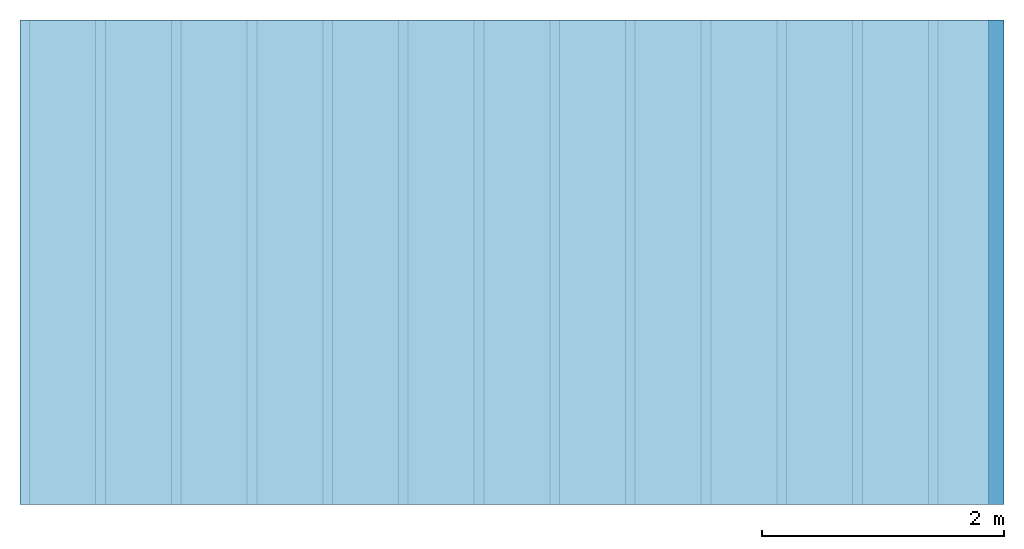
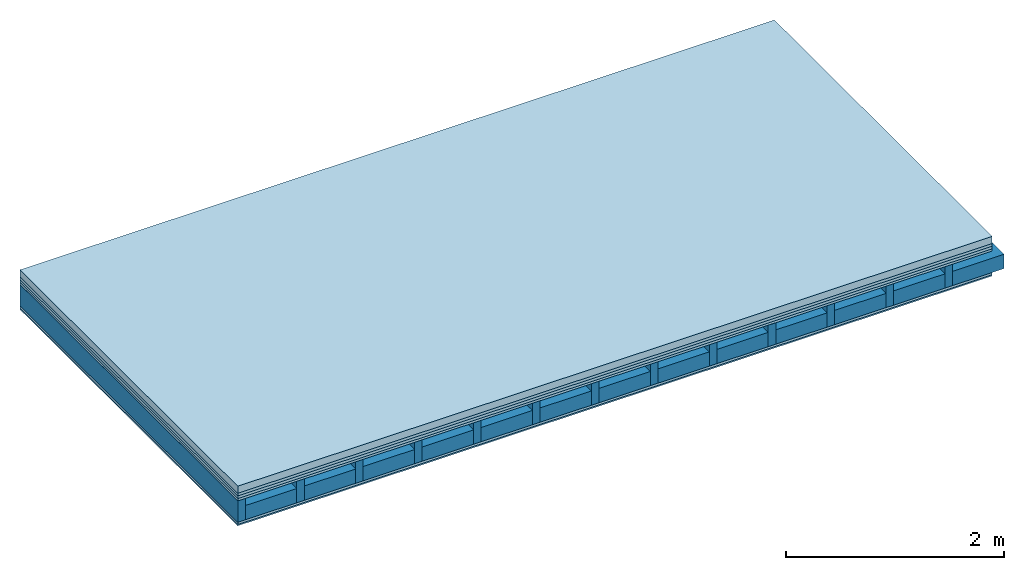
# One storey: 6 plates, 2 members, 1 element without a shape of its own.
"""IFC4 building model written with IfcOpenShell, lengths in metres."""

from ifc_helpers import new_model, si_unit, derived_unit, direction, frame, frame_2d, origin, origin_with_axes, place, context, project, spatial, rectangle, extrude, material, layer, layer_set, type_object, element, aggregate, save


model = new_model("IFC4")

# Units and contexts
plan_context = context("Plan", 3, precision=1e-05, world=origin(), true_north=direction((0.0, 1.0)))
model_context = context("Model", 3, precision=1e-05, world=origin(), true_north=direction((0.0, 1.0)))
ifc_project = project(units=[si_unit("LENGTHUNIT", "METRE"), derived_unit("SOUNDPRESSUREUNIT", [(si_unit("PRESSUREUNIT", "PASCAL", prefix="MICRO"), 0)]), si_unit("ENERGYUNIT", "JOULE", prefix="MEGA"), si_unit("MASSUNIT", "GRAM", prefix="KILO"), derived_unit("THERMALTRANSMITTANCEUNIT", [(si_unit("POWERUNIT", "WATT"), 1), (si_unit("AREAUNIT", "SQUARE_METRE"), -1), (si_unit("THERMODYNAMICTEMPERATUREUNIT", "KELVIN"), -1)]), derived_unit("AREADENSITYUNIT", [(si_unit("MASSUNIT", "GRAM", prefix="KILO"), 1), (si_unit("AREAUNIT", "SQUARE_METRE"), -1)]), derived_unit("USERDEFINED", [(si_unit("ENERGYUNIT", "JOULE", prefix="MEGA"), 1), (si_unit("AREAUNIT", "SQUARE_METRE"), -1)])], contexts=[plan_context, model_context])

# Site, building, storey
site = spatial("IfcSite", under=ifc_project)
building_placement = place(None, origin())
building = spatial("IfcBuilding", under=site, at=building_placement)
storey_placement = place(building_placement, origin())
storey = spatial("IfcBuildingStorey", under=building, at=storey_placement)

# Slab, members, plates
ifc_material_1 = material(Name="Cement screed", Category="04.006")
ifc_layer_1 = layer(ifc_material_1, 0.08, Name="On-material")
ifc_material_2 = material()
ifc_layer_2 = layer(ifc_material_2, 0.03, Name="Impact sound insulation")
ifc_material_3 = material()
ifc_layer_3 = layer(ifc_material_3, 0.03, Name="Additional insulation")
ifc_material_4 = material(Category="07.001")
ifc_layer_4 = layer(ifc_material_4, 0.025, Name="Sub-floor")
ifc_material_5 = material(Name="Rigid, of the art")
ifc_layer_5 = layer(ifc_material_5, 0.0, Name="Bond")
ifc_layer_6 = layer(None, 0.24, Name="Supporting structure")
ifc_layer_7 = layer(ifc_material_5, 0.0, Name="Bond")
ifc_layer_8 = layer(ifc_material_4, 0.025, Name="Lower layer 1")
ifc_material_6 = material(Category="03.007")
ifc_layer_9 = layer(ifc_material_6, 0.015, Name="Lower 2nd layer")
ifc_layer_set = layer_set([ifc_layer_1, ifc_layer_2, ifc_layer_3, ifc_layer_4, ifc_layer_5, ifc_layer_6, ifc_layer_7, ifc_layer_8, ifc_layer_9])
slab_type = type_object("IfcSlabType", Name="A0455", PredefinedType="NOTDEFINED", material=ifc_layer_set)
slab_placement = place(None, frame((0.0, 0.0, 0.0), z_axis=(0.0, 0.0, -1.0), x_axis=(1.0, 0.0, 0.0)))
slab = element("IfcSlab", 1, at=slab_placement, inside=storey, type_object=slab_type, material=ifc_layer_set, Name="Slab #1")
ifc_material_7 = material()
member_1_placement = place(slab_placement, origin())
member_1 = element("IfcMember", 2, at=member_1_placement, material=ifc_material_7, Name="Supporting structure", context=plan_context, shape_type="SweptSolid", body=[
    extrude(rectangle(XDim=0.08, YDim=0.24, at=frame_2d((0.04, 0.12), x_axis=(1.0, 0.0))), frame((0.0, 4.0, 0.165), z_axis=(0.0, -1.0, 0.0), x_axis=(1.0, 0.0, 0.0)), (0.0, 0.0, 1.0), 4.0),
    extrude(rectangle(XDim=0.08, YDim=0.24, at=frame_2d((0.04, 0.12), x_axis=(1.0, 0.0))), frame((0.625, 4.0, 0.165), z_axis=(0.0, -1.0, 0.0), x_axis=(1.0, 0.0, 0.0)), (0.0, 0.0, 1.0), 4.0),
    extrude(rectangle(XDim=0.08, YDim=0.24, at=frame_2d((0.04, 0.12), x_axis=(1.0, 0.0))), frame((1.25, 4.0, 0.165), z_axis=(0.0, -1.0, 0.0), x_axis=(1.0, 0.0, 0.0)), (0.0, 0.0, 1.0), 4.0),
    extrude(rectangle(XDim=0.08, YDim=0.24, at=frame_2d((0.04, 0.12), x_axis=(1.0, 0.0))), frame((1.875, 4.0, 0.165), z_axis=(0.0, -1.0, 0.0), x_axis=(1.0, 0.0, 0.0)), (0.0, 0.0, 1.0), 4.0),
    extrude(rectangle(XDim=0.08, YDim=0.24, at=frame_2d((0.04, 0.12), x_axis=(1.0, 0.0))), frame((2.5, 4.0, 0.165), z_axis=(0.0, -1.0, 0.0), x_axis=(1.0, 0.0, 0.0)), (0.0, 0.0, 1.0), 4.0),
    extrude(rectangle(XDim=0.08, YDim=0.24, at=frame_2d((0.04, 0.12), x_axis=(1.0, 0.0))), frame((3.125, 4.0, 0.165), z_axis=(0.0, -1.0, 0.0), x_axis=(1.0, 0.0, 0.0)), (0.0, 0.0, 1.0), 4.0),
    extrude(rectangle(XDim=0.08, YDim=0.24, at=frame_2d((0.04, 0.12), x_axis=(1.0, 0.0))), frame((3.75, 4.0, 0.165), z_axis=(0.0, -1.0, 0.0), x_axis=(1.0, 0.0, 0.0)), (0.0, 0.0, 1.0), 4.0),
    extrude(rectangle(XDim=0.08, YDim=0.24, at=frame_2d((0.04, 0.12), x_axis=(1.0, 0.0))), frame((4.375, 4.0, 0.165), z_axis=(0.0, -1.0, 0.0), x_axis=(1.0, 0.0, 0.0)), (0.0, 0.0, 1.0), 4.0),
    extrude(rectangle(XDim=0.08, YDim=0.24, at=frame_2d((0.04, 0.12), x_axis=(1.0, 0.0))), frame((5.0, 4.0, 0.165), z_axis=(0.0, -1.0, 0.0), x_axis=(1.0, 0.0, 0.0)), (0.0, 0.0, 1.0), 4.0),
    extrude(rectangle(XDim=0.08, YDim=0.24, at=frame_2d((0.04, 0.12), x_axis=(1.0, 0.0))), frame((5.625, 4.0, 0.165), z_axis=(0.0, -1.0, 0.0), x_axis=(1.0, 0.0, 0.0)), (0.0, 0.0, 1.0), 4.0),
    extrude(rectangle(XDim=0.08, YDim=0.24, at=frame_2d((0.04, 0.12), x_axis=(1.0, 0.0))), frame((6.25, 4.0, 0.165), z_axis=(0.0, -1.0, 0.0), x_axis=(1.0, 0.0, 0.0)), (0.0, 0.0, 1.0), 4.0),
    extrude(rectangle(XDim=0.08, YDim=0.24, at=frame_2d((0.04, 0.12), x_axis=(1.0, 0.0))), frame((6.875, 4.0, 0.165), z_axis=(0.0, -1.0, 0.0), x_axis=(1.0, 0.0, 0.0)), (0.0, 0.0, 1.0), 4.0),
    extrude(rectangle(XDim=0.08, YDim=0.24, at=frame_2d((0.04, 0.12), x_axis=(1.0, 0.0))), frame((7.5, 4.0, 0.165), z_axis=(0.0, -1.0, 0.0), x_axis=(1.0, 0.0, 0.0)), (0.0, 0.0, 1.0), 4.0),
])
ifc_material_8 = material()
member_2_placement = place(slab_placement, origin())
member_2 = element("IfcMember", 3, at=member_2_placement, material=ifc_material_8, Name="in supporting structure", context=plan_context, shape_type="SweptSolid", body=[
    extrude(rectangle(XDim=0.545, YDim=0.16, at=frame_2d((0.2725, 0.08), x_axis=(1.0, 0.0))), frame((0.08, 4.0, 0.245), z_axis=(0.0, -1.0, 0.0), x_axis=(1.0, 0.0, 0.0)), (0.0, 0.0, 1.0), 4.0),
    extrude(rectangle(XDim=0.545, YDim=0.16, at=frame_2d((0.2725, 0.08), x_axis=(1.0, 0.0))), frame((0.705, 4.0, 0.245), z_axis=(0.0, -1.0, 0.0), x_axis=(1.0, 0.0, 0.0)), (0.0, 0.0, 1.0), 4.0),
    extrude(rectangle(XDim=0.545, YDim=0.16, at=frame_2d((0.2725, 0.08), x_axis=(1.0, 0.0))), frame((1.33, 4.0, 0.245), z_axis=(0.0, -1.0, 0.0), x_axis=(1.0, 0.0, 0.0)), (0.0, 0.0, 1.0), 4.0),
    extrude(rectangle(XDim=0.545, YDim=0.16, at=frame_2d((0.2725, 0.08), x_axis=(1.0, 0.0))), frame((1.955, 4.0, 0.245), z_axis=(0.0, -1.0, 0.0), x_axis=(1.0, 0.0, 0.0)), (0.0, 0.0, 1.0), 4.0),
    extrude(rectangle(XDim=0.545, YDim=0.16, at=frame_2d((0.2725, 0.08), x_axis=(1.0, 0.0))), frame((2.58, 4.0, 0.245), z_axis=(0.0, -1.0, 0.0), x_axis=(1.0, 0.0, 0.0)), (0.0, 0.0, 1.0), 4.0),
    extrude(rectangle(XDim=0.545, YDim=0.16, at=frame_2d((0.2725, 0.08), x_axis=(1.0, 0.0))), frame((3.205, 4.0, 0.245), z_axis=(0.0, -1.0, 0.0), x_axis=(1.0, 0.0, 0.0)), (0.0, 0.0, 1.0), 4.0),
    extrude(rectangle(XDim=0.545, YDim=0.16, at=frame_2d((0.2725, 0.08), x_axis=(1.0, 0.0))), frame((3.83, 4.0, 0.245), z_axis=(0.0, -1.0, 0.0), x_axis=(1.0, 0.0, 0.0)), (0.0, 0.0, 1.0), 4.0),
    extrude(rectangle(XDim=0.545, YDim=0.16, at=frame_2d((0.2725, 0.08), x_axis=(1.0, 0.0))), frame((4.455, 4.0, 0.245), z_axis=(0.0, -1.0, 0.0), x_axis=(1.0, 0.0, 0.0)), (0.0, 0.0, 1.0), 4.0),
    extrude(rectangle(XDim=0.545, YDim=0.16, at=frame_2d((0.2725, 0.08), x_axis=(1.0, 0.0))), frame((5.08, 4.0, 0.245), z_axis=(0.0, -1.0, 0.0), x_axis=(1.0, 0.0, 0.0)), (0.0, 0.0, 1.0), 4.0),
    extrude(rectangle(XDim=0.545, YDim=0.16, at=frame_2d((0.2725, 0.08), x_axis=(1.0, 0.0))), frame((5.705, 4.0, 0.245), z_axis=(0.0, -1.0, 0.0), x_axis=(1.0, 0.0, 0.0)), (0.0, 0.0, 1.0), 4.0),
    extrude(rectangle(XDim=0.545, YDim=0.16, at=frame_2d((0.2725, 0.08), x_axis=(1.0, 0.0))), frame((6.33, 4.0, 0.245), z_axis=(0.0, -1.0, 0.0), x_axis=(1.0, 0.0, 0.0)), (0.0, 0.0, 1.0), 4.0),
    extrude(rectangle(XDim=0.545, YDim=0.16, at=frame_2d((0.2725, 0.08), x_axis=(1.0, 0.0))), frame((6.955, 4.0, 0.245), z_axis=(0.0, -1.0, 0.0), x_axis=(1.0, 0.0, 0.0)), (0.0, 0.0, 1.0), 4.0),
    extrude(rectangle(XDim=0.545, YDim=0.16, at=frame_2d((0.2725, 0.08), x_axis=(1.0, 0.0))), frame((7.58, 4.0, 0.245), z_axis=(0.0, -1.0, 0.0), x_axis=(1.0, 0.0, 0.0)), (0.0, 0.0, 1.0), 4.0),
])
plate_1_placement = place(slab_placement, origin())
plate_1 = element("IfcPlate", 4, at=plate_1_placement, material=ifc_material_1, Name="On-material", context=plan_context, shape_type="SweptSolid", body=[
    extrude(rectangle(XDim=8.0, YDim=4.0, at=frame_2d((4.0, 2.0), x_axis=(1.0, 0.0))), origin_with_axes(), (0.0, 0.0, 1.0), 0.08),
])
plate_2_placement = place(slab_placement, origin())
plate_2 = element("IfcPlate", 5, at=plate_2_placement, material=ifc_material_2, Name="Impact sound insulation", context=plan_context, shape_type="SweptSolid", body=[
    extrude(rectangle(XDim=8.0, YDim=4.0, at=frame_2d((4.0, 2.0), x_axis=(1.0, 0.0))), frame((0.0, 0.0, 0.08), z_axis=(0.0, 0.0, 1.0), x_axis=(1.0, 0.0, 0.0)), (0.0, 0.0, 1.0), 0.03),
])
plate_3_placement = place(slab_placement, origin())
plate_3 = element("IfcPlate", 6, at=plate_3_placement, material=ifc_material_3, Name="Additional insulation", context=plan_context, shape_type="SweptSolid", body=[
    extrude(rectangle(XDim=8.0, YDim=4.0, at=frame_2d((4.0, 2.0), x_axis=(1.0, 0.0))), frame((0.0, 0.0, 0.11), z_axis=(0.0, 0.0, 1.0), x_axis=(1.0, 0.0, 0.0)), (0.0, 0.0, 1.0), 0.03),
])
plate_4_placement = place(slab_placement, origin())
plate_4 = element("IfcPlate", 7, at=plate_4_placement, material=ifc_material_4, Name="Sub-floor", context=plan_context, shape_type="SweptSolid", body=[
    extrude(rectangle(XDim=8.0, YDim=4.0, at=frame_2d((4.0, 2.0), x_axis=(1.0, 0.0))), frame((0.0, 0.0, 0.14), z_axis=(0.0, 0.0, 1.0), x_axis=(1.0, 0.0, 0.0)), (0.0, 0.0, 1.0), 0.025),
])
plate_5_placement = place(slab_placement, origin())
plate_5 = element("IfcPlate", 8, at=plate_5_placement, material=ifc_material_4, Name="Lower layer 1", context=plan_context, shape_type="SweptSolid", body=[
    extrude(rectangle(XDim=8.0, YDim=4.0, at=frame_2d((4.0, 2.0), x_axis=(1.0, 0.0))), frame((0.0, 0.0, 0.405), z_axis=(0.0, 0.0, 1.0), x_axis=(1.0, 0.0, 0.0)), (0.0, 0.0, 1.0), 0.025),
])
plate_6_placement = place(slab_placement, origin())
plate_6 = element("IfcPlate", 9, at=plate_6_placement, material=ifc_material_6, Name="Lower 2nd layer", context=plan_context, shape_type="SweptSolid", body=[
    extrude(rectangle(XDim=8.0, YDim=4.0, at=frame_2d((4.0, 2.0), x_axis=(1.0, 0.0))), frame((0.0, 0.0, 0.43), z_axis=(0.0, 0.0, 1.0), x_axis=(1.0, 0.0, 0.0)), (0.0, 0.0, 1.0), 0.015),
])
aggregate(slab, [plate_1, plate_2, plate_3, plate_4, member_1, member_2, plate_5, plate_6])

save(model, "model.ifc")
